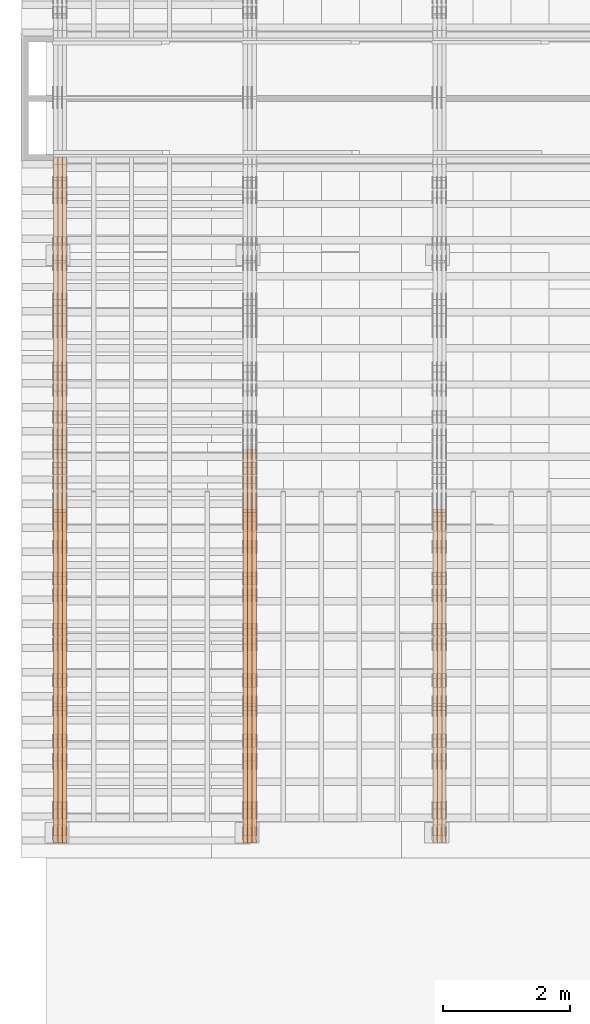
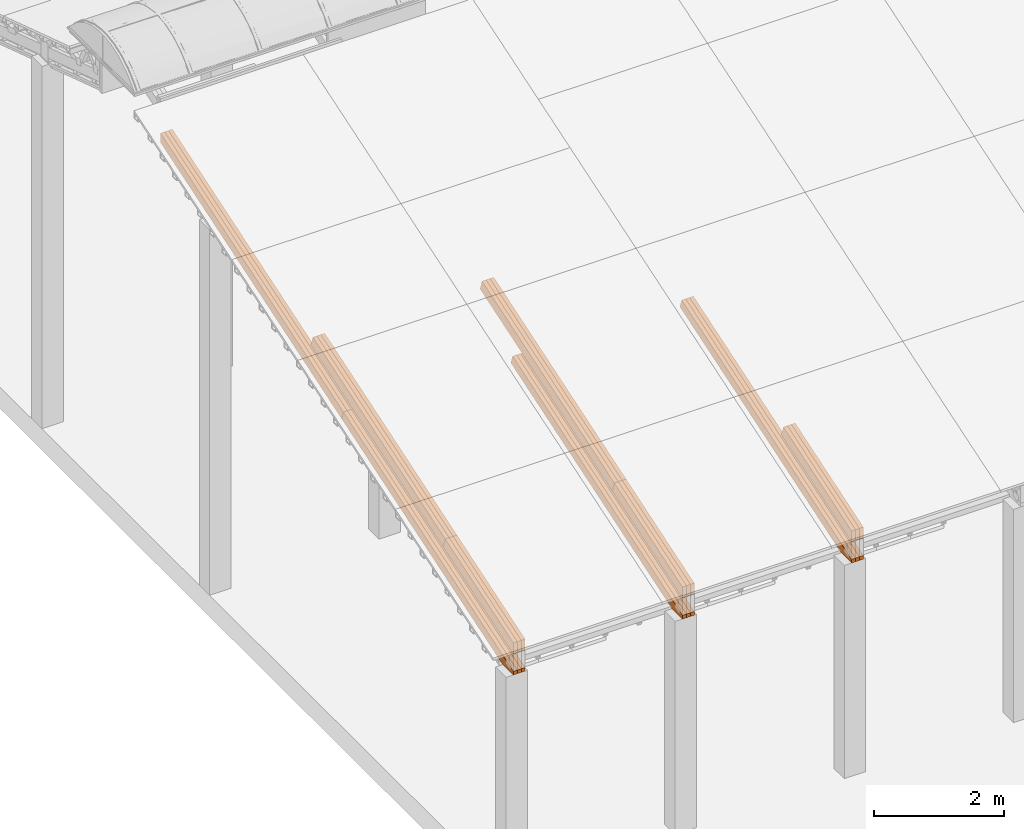
# One storey, part 11 of 385: 27 proxies.
"""IFC2X3 building model written with IfcOpenShell, lengths in millimetres."""

from ifc_helpers import new_model, entity, si_unit, converted_unit, derived_unit, direction, frame, origin, place, context, subcontext, project, spatial, polyline, outline, extrude, source, transform, mapped, material, type_object, type_shapes, element, save


model = new_model("IFC2X3")

# Units and contexts
model_context = context("Model", 3, precision=0.01, world=origin(), true_north=direction((6.12303176911189e-17, 1.0)))
body_context = subcontext(model_context, "Body", "Model", "MODEL_VIEW")
ifc_project = project(units=[si_unit("LENGTHUNIT", "METRE", prefix="MILLI"), si_unit("AREAUNIT", "SQUARE_METRE"), si_unit("VOLUMEUNIT", "CUBIC_METRE"), converted_unit("PLANEANGLEUNIT", "DEGREE", entity("IfcRatioMeasure", 0.0174532925199433), si_unit("PLANEANGLEUNIT", "RADIAN"), dimensions=[0, 0, 0, 0, 0, 0, 0]), si_unit("MASSUNIT", "GRAM", prefix="KILO"), derived_unit("MASSDENSITYUNIT", [(si_unit("MASSUNIT", "GRAM", prefix="KILO"), 1), (si_unit("LENGTHUNIT", "METRE"), -3)]), si_unit("TIMEUNIT", "SECOND"), si_unit("FREQUENCYUNIT", "HERTZ"), si_unit("THERMODYNAMICTEMPERATUREUNIT", "DEGREE_CELSIUS"), derived_unit("THERMALTRANSMITTANCEUNIT", [(si_unit("MASSUNIT", "GRAM", prefix="KILO"), 1), (si_unit("THERMODYNAMICTEMPERATUREUNIT", "KELVIN"), -1), (si_unit("TIMEUNIT", "SECOND"), -3)]), derived_unit("VOLUMETRICFLOWRATEUNIT", [(si_unit("LENGTHUNIT", "METRE"), 3), (si_unit("TIMEUNIT", "SECOND"), -1)]), si_unit("ELECTRICCURRENTUNIT", "AMPERE"), si_unit("ELECTRICVOLTAGEUNIT", "VOLT"), si_unit("POWERUNIT", "WATT"), si_unit("FORCEUNIT", "NEWTON", prefix="KILO"), si_unit("ILLUMINANCEUNIT", "LUX"), si_unit("LUMINOUSFLUXUNIT", "LUMEN"), si_unit("LUMINOUSINTENSITYUNIT", "CANDELA"), derived_unit("USERDEFINED", [(si_unit("MASSUNIT", "GRAM", prefix="KILO"), -1), (si_unit("LENGTHUNIT", "METRE"), -2), (si_unit("TIMEUNIT", "SECOND"), 3), (si_unit("LUMINOUSFLUXUNIT", "LUMEN"), 1)]), derived_unit("LINEARVELOCITYUNIT", [(si_unit("LENGTHUNIT", "METRE"), 1), (si_unit("TIMEUNIT", "SECOND"), -1)]), si_unit("PRESSUREUNIT", "PASCAL"), derived_unit("USERDEFINED", [(si_unit("LENGTHUNIT", "METRE"), -2), (si_unit("MASSUNIT", "GRAM", prefix="KILO"), 1), (si_unit("TIMEUNIT", "SECOND"), -2)])], contexts=[model_context])

# Site, building, storey
site_placement = place(None, origin())
site = spatial("IfcSite", under=ifc_project, at=site_placement, CompositionType="ELEMENT")
building_placement = place(site_placement, origin())
building = spatial("IfcBuilding", under=site, at=building_placement, CompositionType="ELEMENT")
storey_placement = place(building_placement, origin())
storey = spatial("IfcBuildingStorey", under=building, at=storey_placement, Name="Default", CompositionType="ELEMENT", Elevation=0.0)

# Proxies
ifc_material_1 = material(Name="IfcSurfaceStyle #76711")
building_element_proxy_type_1 = type_object("IfcBuildingElementProxyType", Name="T1-T3 76709", PredefinedType="NOTDEFINED", material=ifc_material_1)
shared_shape_1 = source(origin(), body_context, "Body", "SweptSolid", [
    extrude(outline(polyline([(-1085.54462735035, -97.5001496742589), (1117.22361141796, -97.5001496742589), (1117.22498157786, 97.5001496742589), (-1148.90396564547, 97.5001496742589), (-1085.54462735035, -97.5001496742589)])), frame((1117.22498157786, 97.5001496742589, 0.0), z_axis=(0.0, 0.0, 1.0), x_axis=(-1.0, 0.0, 0.0)), (0.0, 0.0, 1.0), 69.9999999999999),
])
type_shapes(building_element_proxy_type_1, [shared_shape_1])
proxy_1_placement = place(building_placement, frame((6385.0, 5095.216796875, 1095.23693847656), z_axis=(-1.0, 0.0, 0.0), x_axis=(0.0, -0.951056516295154, -0.309016994374948)))
element("IfcBuildingElementProxy", 1, at=proxy_1_placement, inside=storey, type_object=building_element_proxy_type_1, material=ifc_material_1, Name="T1-T3", context=body_context, shape_type="MappedRepresentation", body=[
    mapped(shared_shape_1, transform((0.0, 0.0, 0.0), scale=1.0)),
])
ifc_material_2 = material(Name="IfcSurfaceStyle #76654")
building_element_proxy_type_2 = type_object("IfcBuildingElementProxyType", Name="T1-T3 76652", PredefinedType="NOTDEFINED", material=ifc_material_2)
shared_shape_2 = source(origin(), body_context, "Body", "SweptSolid", [
    extrude(outline(polyline([(-1085.54462735035, -97.5001496742589), (1117.22361141796, -97.5001496742589), (1117.22498157786, 97.5001496742589), (-1148.90396564547, 97.5001496742589), (-1085.54462735035, -97.5001496742589)])), frame((1117.22498157786, 97.5001496742589, 0.0), z_axis=(0.0, 0.0, 1.0), x_axis=(-1.0, 0.0, 0.0)), (0.0, 0.0, 1.0), 69.9999999999999),
])
type_shapes(building_element_proxy_type_2, [shared_shape_2])
proxy_2_placement = place(building_placement, frame((6315.0, 5095.216796875, 1095.23693847656), z_axis=(-1.0, 0.0, 0.0), x_axis=(0.0, -0.951056516295154, -0.309016994374948)))
element("IfcBuildingElementProxy", 2, at=proxy_2_placement, inside=storey, type_object=building_element_proxy_type_2, material=ifc_material_2, Name="T1-T3", context=body_context, shape_type="MappedRepresentation", body=[
    mapped(shared_shape_2, transform((0.0, 0.0, 0.0), scale=1.0)),
])
ifc_material_3 = material(Name="IfcSurfaceStyle #76597")
building_element_proxy_type_3 = type_object("IfcBuildingElementProxyType", Name="T1-T3 76595", PredefinedType="NOTDEFINED", material=ifc_material_3)
shared_shape_3 = source(origin(), body_context, "Body", "SweptSolid", [
    extrude(outline(polyline([(-1085.54462735035, -97.5001496742589), (1117.22361141796, -97.5001496742589), (1117.22498157786, 97.5001496742589), (-1148.90396564547, 97.5001496742589), (-1085.54462735035, -97.5001496742589)])), frame((1117.22498157786, 97.5001496742589, 0.0), z_axis=(0.0, 0.0, 1.0), x_axis=(-1.0, 0.0, 0.0)), (0.0, 0.0, 1.0), 69.9999999999999),
])
type_shapes(building_element_proxy_type_3, [shared_shape_3])
proxy_3_placement = place(building_placement, frame((6245.0, 5095.216796875, 1095.23693847656), z_axis=(-1.0, 0.0, 0.0), x_axis=(0.0, -0.951056516295154, -0.309016994374948)))
element("IfcBuildingElementProxy", 3, at=proxy_3_placement, inside=storey, type_object=building_element_proxy_type_3, material=ifc_material_3, Name="T1-T3", context=body_context, shape_type="MappedRepresentation", body=[
    mapped(shared_shape_3, transform((0.0, 0.0, 0.0), scale=1.0)),
])
ifc_material_4 = material(Name="IfcSurfaceStyle #76027")
building_element_proxy_type_4 = type_object("IfcBuildingElementProxyType", Name="T1-B5 76025", PredefinedType="NOTDEFINED", material=ifc_material_4)
shared_shape_4 = source(origin(), body_context, "Body", "SweptSolid", [
    extrude(outline(polyline([(-3238.20553797979, -89.0131148793731), (1950.26357999126, -89.0131148793731), (2273.6227955316, 16.0525968934038), (2252.52438864378, 80.9868164326712), (-3238.20522618685, 80.9868164326712), (-3238.20553797979, -89.0131148793731)])), frame((2273.6227955316, 80.9869419088758, 0.0), z_axis=(0.0, 0.0, 1.0), x_axis=(-1.0, 0.0, 0.0)), (0.0, 0.0, 1.0), 69.9999999999997),
])
type_shapes(building_element_proxy_type_4, [shared_shape_4])
proxy_4_placement = place(building_placement, frame((6385.0, 2919.93418387161, 61.7562319586341), z_axis=(-1.0, 0.0, 0.0), x_axis=(0.0, 0.951056516295124, 0.309016994375039)))
element("IfcBuildingElementProxy", 4, at=proxy_4_placement, inside=storey, type_object=building_element_proxy_type_4, material=ifc_material_4, Name="T1-B5", context=body_context, shape_type="MappedRepresentation", body=[
    mapped(shared_shape_4, transform((0.0, 0.0, 0.0), scale=1.0)),
])
ifc_material_5 = material(Name="IfcSurfaceStyle #75961")
building_element_proxy_type_5 = type_object("IfcBuildingElementProxyType", Name="T1-B5 75959", PredefinedType="NOTDEFINED", material=ifc_material_5)
shared_shape_5 = source(origin(), body_context, "Body", "SweptSolid", [
    extrude(outline(polyline([(-3238.20553797979, -89.0131148793731), (1950.26357999126, -89.0131148793731), (2273.6227955316, 16.0525968934038), (2252.52438864378, 80.9868164326712), (-3238.20522618685, 80.9868164326712), (-3238.20553797979, -89.0131148793731)])), frame((2273.6227955316, 80.9869419088758, 0.0), z_axis=(0.0, 0.0, 1.0), x_axis=(-1.0, 0.0, 0.0)), (0.0, 0.0, 1.0), 69.9999999999997),
])
type_shapes(building_element_proxy_type_5, [shared_shape_5])
proxy_5_placement = place(building_placement, frame((6315.0, 2919.93418387161, 61.7562319586341), z_axis=(-1.0, 0.0, 0.0), x_axis=(0.0, 0.951056516295124, 0.309016994375039)))
element("IfcBuildingElementProxy", 5, at=proxy_5_placement, inside=storey, type_object=building_element_proxy_type_5, material=ifc_material_5, Name="T1-B5", context=body_context, shape_type="MappedRepresentation", body=[
    mapped(shared_shape_5, transform((0.0, 0.0, 0.0), scale=1.0)),
])
ifc_material_6 = material(Name="IfcSurfaceStyle #75895")
building_element_proxy_type_6 = type_object("IfcBuildingElementProxyType", Name="T1-B5 75893", PredefinedType="NOTDEFINED", material=ifc_material_6)
shared_shape_6 = source(origin(), body_context, "Body", "SweptSolid", [
    extrude(outline(polyline([(-3238.20553797979, -89.0131148793731), (1950.26357999126, -89.0131148793731), (2273.6227955316, 16.0525968934038), (2252.52438864378, 80.9868164326712), (-3238.20522618685, 80.9868164326712), (-3238.20553797979, -89.0131148793731)])), frame((2273.6227955316, 80.9869419088758, 0.0), z_axis=(0.0, 0.0, 1.0), x_axis=(-1.0, 0.0, 0.0)), (0.0, 0.0, 1.0), 69.9999999999997),
])
type_shapes(building_element_proxy_type_6, [shared_shape_6])
proxy_6_placement = place(building_placement, frame((6245.0, 2919.93418387161, 61.7562319586341), z_axis=(-1.0, 0.0, 0.0), x_axis=(0.0, 0.951056516295124, 0.309016994375039)))
element("IfcBuildingElementProxy", 6, at=proxy_6_placement, inside=storey, type_object=building_element_proxy_type_6, material=ifc_material_6, Name="T1-B5", context=body_context, shape_type="MappedRepresentation", body=[
    mapped(shared_shape_6, transform((0.0, 0.0, 0.0), scale=1.0)),
])
ifc_material_7 = material(Name="IfcSurfaceStyle #42279")
building_element_proxy_type_7 = type_object("IfcBuildingElementProxyType", Name="T1-T3 42277", PredefinedType="NOTDEFINED", material=ifc_material_7)
shared_shape_7 = source(origin(), body_context, "Body", "SweptSolid", [
    extrude(outline(polyline([(-1085.54462735035, -97.5001496742589), (1117.22361141796, -97.5001496742589), (1117.22498157786, 97.5001496742589), (-1148.90396564547, 97.5001496742589), (-1085.54462735035, -97.5001496742589)])), frame((1117.22498157786, 97.5001496742589, 0.0), z_axis=(0.0, 0.0, 1.0), x_axis=(-1.0, 0.0, 0.0)), (0.0, 0.0, 1.0), 69.9999999999999),
])
type_shapes(building_element_proxy_type_7, [shared_shape_7])
proxy_7_placement = place(building_placement, frame((3385.0, 5095.216796875, 1095.23693847656), z_axis=(-1.0, 0.0, 0.0), x_axis=(0.0, -0.951056516295154, -0.309016994374948)))
element("IfcBuildingElementProxy", 7, at=proxy_7_placement, inside=storey, type_object=building_element_proxy_type_7, material=ifc_material_7, Name="T1-T3", context=body_context, shape_type="MappedRepresentation", body=[
    mapped(shared_shape_7, transform((0.0, 0.0, 0.0), scale=1.0)),
])
ifc_material_8 = material(Name="IfcSurfaceStyle #42222")
building_element_proxy_type_8 = type_object("IfcBuildingElementProxyType", Name="T1-T3 42220", PredefinedType="NOTDEFINED", material=ifc_material_8)
shared_shape_8 = source(origin(), body_context, "Body", "SweptSolid", [
    extrude(outline(polyline([(-1085.54462735035, -97.5001496742589), (1117.22361141796, -97.5001496742589), (1117.22498157786, 97.5001496742589), (-1148.90396564547, 97.5001496742589), (-1085.54462735035, -97.5001496742589)])), frame((1117.22498157786, 97.5001496742589, 0.0), z_axis=(0.0, 0.0, 1.0), x_axis=(-1.0, 0.0, 0.0)), (0.0, 0.0, 1.0), 69.9999999999999),
])
type_shapes(building_element_proxy_type_8, [shared_shape_8])
proxy_8_placement = place(building_placement, frame((3315.0, 5095.216796875, 1095.23693847656), z_axis=(-1.0, 0.0, 0.0), x_axis=(0.0, -0.951056516295154, -0.309016994374948)))
element("IfcBuildingElementProxy", 8, at=proxy_8_placement, inside=storey, type_object=building_element_proxy_type_8, material=ifc_material_8, Name="T1-T3", context=body_context, shape_type="MappedRepresentation", body=[
    mapped(shared_shape_8, transform((0.0, 0.0, 0.0), scale=1.0)),
])
ifc_material_9 = material(Name="IfcSurfaceStyle #42165")
building_element_proxy_type_9 = type_object("IfcBuildingElementProxyType", Name="T1-T3 42163", PredefinedType="NOTDEFINED", material=ifc_material_9)
shared_shape_9 = source(origin(), body_context, "Body", "SweptSolid", [
    extrude(outline(polyline([(-1085.54462735035, -97.5001496742589), (1117.22361141796, -97.5001496742589), (1117.22498157786, 97.5001496742589), (-1148.90396564547, 97.5001496742589), (-1085.54462735035, -97.5001496742589)])), frame((1117.22498157786, 97.5001496742589, 0.0), z_axis=(0.0, 0.0, 1.0), x_axis=(-1.0, 0.0, 0.0)), (0.0, 0.0, 1.0), 69.9999999999999),
])
type_shapes(building_element_proxy_type_9, [shared_shape_9])
proxy_9_placement = place(building_placement, frame((3245.0, 5095.216796875, 1095.23693847656), z_axis=(-1.0, 0.0, 0.0), x_axis=(0.0, -0.951056516295154, -0.309016994374948)))
element("IfcBuildingElementProxy", 9, at=proxy_9_placement, inside=storey, type_object=building_element_proxy_type_9, material=ifc_material_9, Name="T1-T3", context=body_context, shape_type="MappedRepresentation", body=[
    mapped(shared_shape_9, transform((0.0, 0.0, 0.0), scale=1.0)),
])
ifc_material_10 = material(Name="IfcSurfaceStyle #42108")
building_element_proxy_type_10 = type_object("IfcBuildingElementProxyType", Name="T1-T2 42106", PredefinedType="NOTDEFINED", material=ifc_material_10)
shared_shape_10 = source(origin(), body_context, "Body", "SweptSolid", [
    extrude(outline(polyline([(-2137.04475371072, -97.5001541485635), (2137.04431231695, -97.5001541485635), (2137.0438249446, 97.5001541485636), (-2137.04338355082, 97.5001541485635), (-2137.04475371072, -97.5001541485635)])), frame((2137.04431231695, 97.5003268035489, 0.0), z_axis=(0.0, 0.0, 1.0), x_axis=(-1.0, 0.0, 0.0)), (0.0, 0.0, 1.0), 69.9999999999997),
])
type_shapes(building_element_proxy_type_10, [shared_shape_10])
proxy_10_placement = place(building_placement, frame((3385.0, 9160.11575124697, 2416.00267194857), z_axis=(-1.0, 0.0, 0.0), x_axis=(0.0, -0.951056516295154, -0.309016994374948)))
element("IfcBuildingElementProxy", 10, at=proxy_10_placement, inside=storey, type_object=building_element_proxy_type_10, material=ifc_material_10, Name="T1-T2", context=body_context, shape_type="MappedRepresentation", body=[
    mapped(shared_shape_10, transform((0.0, 0.0, 0.0), scale=1.0)),
])
ifc_material_11 = material(Name="IfcSurfaceStyle #42051")
building_element_proxy_type_11 = type_object("IfcBuildingElementProxyType", Name="T1-T2 42049", PredefinedType="NOTDEFINED", material=ifc_material_11)
shared_shape_11 = source(origin(), body_context, "Body", "SweptSolid", [
    extrude(outline(polyline([(-2137.04475371072, -97.5001541485635), (2137.04431231695, -97.5001541485635), (2137.0438249446, 97.5001541485636), (-2137.04338355082, 97.5001541485635), (-2137.04475371072, -97.5001541485635)])), frame((2137.04431231695, 97.5003268035489, 0.0), z_axis=(0.0, 0.0, 1.0), x_axis=(-1.0, 0.0, 0.0)), (0.0, 0.0, 1.0), 69.9999999999997),
])
type_shapes(building_element_proxy_type_11, [shared_shape_11])
proxy_11_placement = place(building_placement, frame((3315.0, 9160.11575124697, 2416.00267194857), z_axis=(-1.0, 0.0, 0.0), x_axis=(0.0, -0.951056516295154, -0.309016994374948)))
element("IfcBuildingElementProxy", 11, at=proxy_11_placement, inside=storey, type_object=building_element_proxy_type_11, material=ifc_material_11, Name="T1-T2", context=body_context, shape_type="MappedRepresentation", body=[
    mapped(shared_shape_11, transform((0.0, 0.0, 0.0), scale=1.0)),
])
ifc_material_12 = material(Name="IfcSurfaceStyle #41994")
building_element_proxy_type_12 = type_object("IfcBuildingElementProxyType", Name="T1-T2 41992", PredefinedType="NOTDEFINED", material=ifc_material_12)
shared_shape_12 = source(origin(), body_context, "Body", "SweptSolid", [
    extrude(outline(polyline([(-2137.04475371072, -97.5001541485635), (2137.04431231695, -97.5001541485635), (2137.0438249446, 97.5001541485636), (-2137.04338355082, 97.5001541485635), (-2137.04475371072, -97.5001541485635)])), frame((2137.04431231695, 97.5003268035489, 0.0), z_axis=(0.0, 0.0, 1.0), x_axis=(-1.0, 0.0, 0.0)), (0.0, 0.0, 1.0), 69.9999999999997),
])
type_shapes(building_element_proxy_type_12, [shared_shape_12])
proxy_12_placement = place(building_placement, frame((3245.0, 9160.11575124697, 2416.00267194857), z_axis=(-1.0, 0.0, 0.0), x_axis=(0.0, -0.951056516295154, -0.309016994374948)))
element("IfcBuildingElementProxy", 12, at=proxy_12_placement, inside=storey, type_object=building_element_proxy_type_12, material=ifc_material_12, Name="T1-T2", context=body_context, shape_type="MappedRepresentation", body=[
    mapped(shared_shape_12, transform((0.0, 0.0, 0.0), scale=1.0)),
])
ifc_material_13 = material(Name="IfcSurfaceStyle #41595")
building_element_proxy_type_13 = type_object("IfcBuildingElementProxyType", Name="T1-B5 41593", PredefinedType="NOTDEFINED", material=ifc_material_13)
shared_shape_13 = source(origin(), body_context, "Body", "SweptSolid", [
    extrude(outline(polyline([(-3238.20553797979, -89.0131148793731), (1950.26357999126, -89.0131148793731), (2273.6227955316, 16.0525968934038), (2252.52438864378, 80.9868164326712), (-3238.20522618685, 80.9868164326712), (-3238.20553797979, -89.0131148793731)])), frame((2273.6227955316, 80.9869419088758, 0.0), z_axis=(0.0, 0.0, 1.0), x_axis=(-1.0, 0.0, 0.0)), (0.0, 0.0, 1.0), 69.9999999999997),
])
type_shapes(building_element_proxy_type_13, [shared_shape_13])
proxy_13_placement = place(building_placement, frame((3385.0, 2919.93418387161, 61.7562319586341), z_axis=(-1.0, 0.0, 0.0), x_axis=(0.0, 0.951056516295124, 0.309016994375039)))
element("IfcBuildingElementProxy", 13, at=proxy_13_placement, inside=storey, type_object=building_element_proxy_type_13, material=ifc_material_13, Name="T1-B5", context=body_context, shape_type="MappedRepresentation", body=[
    mapped(shared_shape_13, transform((0.0, 0.0, 0.0), scale=1.0)),
])
ifc_material_14 = material(Name="IfcSurfaceStyle #41529")
building_element_proxy_type_14 = type_object("IfcBuildingElementProxyType", Name="T1-B5 41527", PredefinedType="NOTDEFINED", material=ifc_material_14)
shared_shape_14 = source(origin(), body_context, "Body", "SweptSolid", [
    extrude(outline(polyline([(-3238.20553797979, -89.0131148793731), (1950.26357999126, -89.0131148793731), (2273.6227955316, 16.0525968934038), (2252.52438864378, 80.9868164326712), (-3238.20522618685, 80.9868164326712), (-3238.20553797979, -89.0131148793731)])), frame((2273.6227955316, 80.9869419088758, 0.0), z_axis=(0.0, 0.0, 1.0), x_axis=(-1.0, 0.0, 0.0)), (0.0, 0.0, 1.0), 69.9999999999997),
])
type_shapes(building_element_proxy_type_14, [shared_shape_14])
proxy_14_placement = place(building_placement, frame((3315.0, 2919.93418387161, 61.7562319586341), z_axis=(-1.0, 0.0, 0.0), x_axis=(0.0, 0.951056516295124, 0.309016994375039)))
element("IfcBuildingElementProxy", 14, at=proxy_14_placement, inside=storey, type_object=building_element_proxy_type_14, material=ifc_material_14, Name="T1-B5", context=body_context, shape_type="MappedRepresentation", body=[
    mapped(shared_shape_14, transform((0.0, 0.0, 0.0), scale=1.0)),
])
ifc_material_15 = material(Name="IfcSurfaceStyle #41463")
building_element_proxy_type_15 = type_object("IfcBuildingElementProxyType", Name="T1-B5 41461", PredefinedType="NOTDEFINED", material=ifc_material_15)
shared_shape_15 = source(origin(), body_context, "Body", "SweptSolid", [
    extrude(outline(polyline([(-3238.20553797979, -89.0131148793731), (1950.26357999126, -89.0131148793731), (2273.6227955316, 16.0525968934038), (2252.52438864378, 80.9868164326712), (-3238.20522618685, 80.9868164326712), (-3238.20553797979, -89.0131148793731)])), frame((2273.6227955316, 80.9869419088758, 0.0), z_axis=(0.0, 0.0, 1.0), x_axis=(-1.0, 0.0, 0.0)), (0.0, 0.0, 1.0), 69.9999999999997),
])
type_shapes(building_element_proxy_type_15, [shared_shape_15])
proxy_15_placement = place(building_placement, frame((3245.0, 2919.93418387161, 61.7562319586341), z_axis=(-1.0, 0.0, 0.0), x_axis=(0.0, 0.951056516295124, 0.309016994375039)))
element("IfcBuildingElementProxy", 15, at=proxy_15_placement, inside=storey, type_object=building_element_proxy_type_15, material=ifc_material_15, Name="T1-B5", context=body_context, shape_type="MappedRepresentation", body=[
    mapped(shared_shape_15, transform((0.0, 0.0, 0.0), scale=1.0)),
])
ifc_material_16 = material(Name="IfcSurfaceStyle #7847")
building_element_proxy_type_16 = type_object("IfcBuildingElementProxyType", Name="T1-T3 7845", PredefinedType="NOTDEFINED", material=ifc_material_16)
shared_shape_16 = source(origin(), body_context, "Body", "SweptSolid", [
    extrude(outline(polyline([(-1085.54462735035, -97.5001496742589), (1117.22361141796, -97.5001496742589), (1117.22498157786, 97.5001496742589), (-1148.90396564547, 97.5001496742589), (-1085.54462735035, -97.5001496742589)])), frame((1117.22498157786, 97.5001496742589, 0.0), z_axis=(0.0, 0.0, 1.0), x_axis=(-1.0, 0.0, 0.0)), (0.0, 0.0, 1.0), 69.9999999999999),
])
type_shapes(building_element_proxy_type_16, [shared_shape_16])
proxy_16_placement = place(building_placement, frame((385.0, 5095.216796875, 1095.23693847656), z_axis=(-1.0, 0.0, 0.0), x_axis=(0.0, -0.951056516295154, -0.309016994374948)))
element("IfcBuildingElementProxy", 16, at=proxy_16_placement, inside=storey, type_object=building_element_proxy_type_16, material=ifc_material_16, Name="T1-T3", context=body_context, shape_type="MappedRepresentation", body=[
    mapped(shared_shape_16, transform((0.0, 0.0, 0.0), scale=1.0)),
])
ifc_material_17 = material(Name="IfcSurfaceStyle #7790")
building_element_proxy_type_17 = type_object("IfcBuildingElementProxyType", Name="T1-T3 7788", PredefinedType="NOTDEFINED", material=ifc_material_17)
shared_shape_17 = source(origin(), body_context, "Body", "SweptSolid", [
    extrude(outline(polyline([(-1085.54462735035, -97.5001496742589), (1117.22361141796, -97.5001496742589), (1117.22498157786, 97.5001496742589), (-1148.90396564547, 97.5001496742589), (-1085.54462735035, -97.5001496742589)])), frame((1117.22498157786, 97.5001496742589, 0.0), z_axis=(0.0, 0.0, 1.0), x_axis=(-1.0, 0.0, 0.0)), (0.0, 0.0, 1.0), 69.9999999999999),
])
type_shapes(building_element_proxy_type_17, [shared_shape_17])
proxy_17_placement = place(building_placement, frame((315.0, 5095.216796875, 1095.23693847656), z_axis=(-1.0, 0.0, 0.0), x_axis=(0.0, -0.951056516295154, -0.309016994374948)))
element("IfcBuildingElementProxy", 17, at=proxy_17_placement, inside=storey, type_object=building_element_proxy_type_17, material=ifc_material_17, Name="T1-T3", context=body_context, shape_type="MappedRepresentation", body=[
    mapped(shared_shape_17, transform((0.0, 0.0, 0.0), scale=1.0)),
])
ifc_material_18 = material(Name="IfcSurfaceStyle #7733")
building_element_proxy_type_18 = type_object("IfcBuildingElementProxyType", Name="T1-T3 7731", PredefinedType="NOTDEFINED", material=ifc_material_18)
shared_shape_18 = source(origin(), body_context, "Body", "SweptSolid", [
    extrude(outline(polyline([(-1085.54462735035, -97.5001496742589), (1117.22361141796, -97.5001496742589), (1117.22498157786, 97.5001496742589), (-1148.90396564547, 97.5001496742589), (-1085.54462735035, -97.5001496742589)])), frame((1117.22498157786, 97.5001496742589, 0.0), z_axis=(0.0, 0.0, 1.0), x_axis=(-1.0, 0.0, 0.0)), (0.0, 0.0, 1.0), 69.9999999999999),
])
type_shapes(building_element_proxy_type_18, [shared_shape_18])
proxy_18_placement = place(building_placement, frame((245.0, 5095.216796875, 1095.23693847656), z_axis=(-1.0, 0.0, 0.0), x_axis=(0.0, -0.951056516295154, -0.309016994374948)))
element("IfcBuildingElementProxy", 18, at=proxy_18_placement, inside=storey, type_object=building_element_proxy_type_18, material=ifc_material_18, Name="T1-T3", context=body_context, shape_type="MappedRepresentation", body=[
    mapped(shared_shape_18, transform((0.0, 0.0, 0.0), scale=1.0)),
])
ifc_material_19 = material(Name="IfcSurfaceStyle #7676")
building_element_proxy_type_19 = type_object("IfcBuildingElementProxyType", Name="T1-T2 7674", PredefinedType="NOTDEFINED", material=ifc_material_19)
shared_shape_19 = source(origin(), body_context, "Body", "SweptSolid", [
    extrude(outline(polyline([(-2137.04475371072, -97.5001541485635), (2137.04431231695, -97.5001541485635), (2137.0438249446, 97.5001541485636), (-2137.04338355082, 97.5001541485635), (-2137.04475371072, -97.5001541485635)])), frame((2137.04431231695, 97.5003268035489, 0.0), z_axis=(0.0, 0.0, 1.0), x_axis=(-1.0, 0.0, 0.0)), (0.0, 0.0, 1.0), 69.9999999999997),
])
type_shapes(building_element_proxy_type_19, [shared_shape_19])
proxy_19_placement = place(building_placement, frame((385.0, 9160.11575124697, 2416.00267194857), z_axis=(-1.0, 0.0, 0.0), x_axis=(0.0, -0.951056516295154, -0.309016994374948)))
element("IfcBuildingElementProxy", 19, at=proxy_19_placement, inside=storey, type_object=building_element_proxy_type_19, material=ifc_material_19, Name="T1-T2", context=body_context, shape_type="MappedRepresentation", body=[
    mapped(shared_shape_19, transform((0.0, 0.0, 0.0), scale=1.0)),
])
ifc_material_20 = material(Name="IfcSurfaceStyle #7619")
building_element_proxy_type_20 = type_object("IfcBuildingElementProxyType", Name="T1-T2 7617", PredefinedType="NOTDEFINED", material=ifc_material_20)
shared_shape_20 = source(origin(), body_context, "Body", "SweptSolid", [
    extrude(outline(polyline([(-2137.04475371072, -97.5001541485635), (2137.04431231695, -97.5001541485635), (2137.0438249446, 97.5001541485636), (-2137.04338355082, 97.5001541485635), (-2137.04475371072, -97.5001541485635)])), frame((2137.04431231695, 97.5003268035489, 0.0), z_axis=(0.0, 0.0, 1.0), x_axis=(-1.0, 0.0, 0.0)), (0.0, 0.0, 1.0), 69.9999999999997),
])
type_shapes(building_element_proxy_type_20, [shared_shape_20])
proxy_20_placement = place(building_placement, frame((315.0, 9160.11575124697, 2416.00267194857), z_axis=(-1.0, 0.0, 0.0), x_axis=(0.0, -0.951056516295154, -0.309016994374948)))
element("IfcBuildingElementProxy", 20, at=proxy_20_placement, inside=storey, type_object=building_element_proxy_type_20, material=ifc_material_20, Name="T1-T2", context=body_context, shape_type="MappedRepresentation", body=[
    mapped(shared_shape_20, transform((0.0, 0.0, 0.0), scale=1.0)),
])
ifc_material_21 = material(Name="IfcSurfaceStyle #7562")
building_element_proxy_type_21 = type_object("IfcBuildingElementProxyType", Name="T1-T2 7560", PredefinedType="NOTDEFINED", material=ifc_material_21)
shared_shape_21 = source(origin(), body_context, "Body", "SweptSolid", [
    extrude(outline(polyline([(-2137.04475371072, -97.5001541485635), (2137.04431231695, -97.5001541485635), (2137.0438249446, 97.5001541485636), (-2137.04338355082, 97.5001541485635), (-2137.04475371072, -97.5001541485635)])), frame((2137.04431231695, 97.5003268035489, 0.0), z_axis=(0.0, 0.0, 1.0), x_axis=(-1.0, 0.0, 0.0)), (0.0, 0.0, 1.0), 69.9999999999997),
])
type_shapes(building_element_proxy_type_21, [shared_shape_21])
proxy_21_placement = place(building_placement, frame((245.0, 9160.11575124697, 2416.00267194857), z_axis=(-1.0, 0.0, 0.0), x_axis=(0.0, -0.951056516295154, -0.309016994374948)))
element("IfcBuildingElementProxy", 21, at=proxy_21_placement, inside=storey, type_object=building_element_proxy_type_21, material=ifc_material_21, Name="T1-T2", context=body_context, shape_type="MappedRepresentation", body=[
    mapped(shared_shape_21, transform((0.0, 0.0, 0.0), scale=1.0)),
])
ifc_material_22 = material(Name="IfcSurfaceStyle #7334")
building_element_proxy_type_22 = type_object("IfcBuildingElementProxyType", Name="T1-B4 7332", PredefinedType="NOTDEFINED", material=ifc_material_22)
shared_shape_22 = source(origin(), body_context, "Body", "SweptSolid", [
    extrude(outline(polyline([(-2912.13310129284, -85.0000958683222), (2939.75111293783, -85.0000958683222), (2939.75142473078, 85.0000958683222), (-2967.36943637577, 85.0000958683222), (-2912.13310129284, -85.0000958683222)])), frame((2939.75142473078, 85.0000958683222, 0.0), z_axis=(0.0, 0.0, 1.0), x_axis=(-1.0, 0.0, 0.0)), (0.0, 0.0, 1.0), 69.9999999999996),
])
type_shapes(building_element_proxy_type_22, [shared_shape_22])
proxy_22_placement = place(building_placement, frame((385.0, 8161.994140625, 1765.00476074219), z_axis=(-1.0, 0.0, 0.0), x_axis=(0.0, 0.951056516295124, 0.309016994375039)))
element("IfcBuildingElementProxy", 22, at=proxy_22_placement, inside=storey, type_object=building_element_proxy_type_22, material=ifc_material_22, Name="T1-B4", context=body_context, shape_type="MappedRepresentation", body=[
    mapped(shared_shape_22, transform((0.0, 0.0, 0.0), scale=1.0)),
])
ifc_material_23 = material(Name="IfcSurfaceStyle #7277")
building_element_proxy_type_23 = type_object("IfcBuildingElementProxyType", Name="T1-B4 7275", PredefinedType="NOTDEFINED", material=ifc_material_23)
shared_shape_23 = source(origin(), body_context, "Body", "SweptSolid", [
    extrude(outline(polyline([(-2912.13310129284, -85.0000958683222), (2939.75111293783, -85.0000958683222), (2939.75142473078, 85.0000958683222), (-2967.36943637577, 85.0000958683222), (-2912.13310129284, -85.0000958683222)])), frame((2939.75142473078, 85.0000958683222, 0.0), z_axis=(0.0, 0.0, 1.0), x_axis=(-1.0, 0.0, 0.0)), (0.0, 0.0, 1.0), 69.9999999999996),
])
type_shapes(building_element_proxy_type_23, [shared_shape_23])
proxy_23_placement = place(building_placement, frame((315.0, 8161.994140625, 1765.00476074219), z_axis=(-1.0, 0.0, 0.0), x_axis=(0.0, 0.951056516295124, 0.309016994375039)))
element("IfcBuildingElementProxy", 23, at=proxy_23_placement, inside=storey, type_object=building_element_proxy_type_23, material=ifc_material_23, Name="T1-B4", context=body_context, shape_type="MappedRepresentation", body=[
    mapped(shared_shape_23, transform((0.0, 0.0, 0.0), scale=1.0)),
])
ifc_material_24 = material(Name="IfcSurfaceStyle #7220")
building_element_proxy_type_24 = type_object("IfcBuildingElementProxyType", Name="T1-B4 7218", PredefinedType="NOTDEFINED", material=ifc_material_24)
shared_shape_24 = source(origin(), body_context, "Body", "SweptSolid", [
    extrude(outline(polyline([(-2912.13310129284, -85.0000958683222), (2939.75111293783, -85.0000958683222), (2939.75142473078, 85.0000958683222), (-2967.36943637577, 85.0000958683222), (-2912.13310129284, -85.0000958683222)])), frame((2939.75142473078, 85.0000958683222, 0.0), z_axis=(0.0, 0.0, 1.0), x_axis=(-1.0, 0.0, 0.0)), (0.0, 0.0, 1.0), 69.9999999999996),
])
type_shapes(building_element_proxy_type_24, [shared_shape_24])
proxy_24_placement = place(building_placement, frame((245.0, 8161.994140625, 1765.00476074219), z_axis=(-1.0, 0.0, 0.0), x_axis=(0.0, 0.951056516295124, 0.309016994375039)))
element("IfcBuildingElementProxy", 24, at=proxy_24_placement, inside=storey, type_object=building_element_proxy_type_24, material=ifc_material_24, Name="T1-B4", context=body_context, shape_type="MappedRepresentation", body=[
    mapped(shared_shape_24, transform((0.0, 0.0, 0.0), scale=1.0)),
])
ifc_material_25 = material(Name="IfcSurfaceStyle #7163")
building_element_proxy_type_25 = type_object("IfcBuildingElementProxyType", Name="T1-B5 7161", PredefinedType="NOTDEFINED", material=ifc_material_25)
shared_shape_25 = source(origin(), body_context, "Body", "SweptSolid", [
    extrude(outline(polyline([(-3238.20553797979, -89.0131148793731), (1950.26357999126, -89.0131148793731), (2273.6227955316, 16.0525968934038), (2252.52438864378, 80.9868164326712), (-3238.20522618685, 80.9868164326712), (-3238.20553797979, -89.0131148793731)])), frame((2273.6227955316, 80.9869419088758, 0.0), z_axis=(0.0, 0.0, 1.0), x_axis=(-1.0, 0.0, 0.0)), (0.0, 0.0, 1.0), 69.9999999999997),
])
type_shapes(building_element_proxy_type_25, [shared_shape_25])
proxy_25_placement = place(building_placement, frame((385.0, 2919.93418387161, 61.7562319586341), z_axis=(-1.0, 0.0, 0.0), x_axis=(0.0, 0.951056516295124, 0.309016994375039)))
element("IfcBuildingElementProxy", 25, at=proxy_25_placement, inside=storey, type_object=building_element_proxy_type_25, material=ifc_material_25, Name="T1-B5", context=body_context, shape_type="MappedRepresentation", body=[
    mapped(shared_shape_25, transform((0.0, 0.0, 0.0), scale=1.0)),
])
ifc_material_26 = material(Name="IfcSurfaceStyle #7097")
building_element_proxy_type_26 = type_object("IfcBuildingElementProxyType", Name="T1-B5 7095", PredefinedType="NOTDEFINED", material=ifc_material_26)
shared_shape_26 = source(origin(), body_context, "Body", "SweptSolid", [
    extrude(outline(polyline([(-3238.20553797979, -89.0131148793731), (1950.26357999126, -89.0131148793731), (2273.6227955316, 16.0525968934038), (2252.52438864378, 80.9868164326712), (-3238.20522618685, 80.9868164326712), (-3238.20553797979, -89.0131148793731)])), frame((2273.6227955316, 80.9869419088758, 0.0), z_axis=(0.0, 0.0, 1.0), x_axis=(-1.0, 0.0, 0.0)), (0.0, 0.0, 1.0), 69.9999999999997),
])
type_shapes(building_element_proxy_type_26, [shared_shape_26])
proxy_26_placement = place(building_placement, frame((315.0, 2919.93418387161, 61.7562319586341), z_axis=(-1.0, 0.0, 0.0), x_axis=(0.0, 0.951056516295124, 0.309016994375039)))
element("IfcBuildingElementProxy", 26, at=proxy_26_placement, inside=storey, type_object=building_element_proxy_type_26, material=ifc_material_26, Name="T1-B5", context=body_context, shape_type="MappedRepresentation", body=[
    mapped(shared_shape_26, transform((0.0, 0.0, 0.0), scale=1.0)),
])
ifc_material_27 = material(Name="IfcSurfaceStyle #7031")
building_element_proxy_type_27 = type_object("IfcBuildingElementProxyType", Name="T1-B5 7029", PredefinedType="NOTDEFINED", material=ifc_material_27)
shared_shape_27 = source(origin(), body_context, "Body", "SweptSolid", [
    extrude(outline(polyline([(-3238.20553797979, -89.0131148793731), (1950.26357999126, -89.0131148793731), (2273.6227955316, 16.0525968934038), (2252.52438864378, 80.9868164326712), (-3238.20522618685, 80.9868164326712), (-3238.20553797979, -89.0131148793731)])), frame((2273.6227955316, 80.9869419088758, 0.0), z_axis=(0.0, 0.0, 1.0), x_axis=(-1.0, 0.0, 0.0)), (0.0, 0.0, 1.0), 69.9999999999997),
])
type_shapes(building_element_proxy_type_27, [shared_shape_27])
proxy_27_placement = place(building_placement, frame((245.0, 2919.93418387161, 61.7562319586341), z_axis=(-1.0, 0.0, 0.0), x_axis=(0.0, 0.951056516295124, 0.309016994375039)))
element("IfcBuildingElementProxy", 27, at=proxy_27_placement, inside=storey, type_object=building_element_proxy_type_27, material=ifc_material_27, Name="T1-B5", context=body_context, shape_type="MappedRepresentation", body=[
    mapped(shared_shape_27, transform((0.0, 0.0, 0.0), scale=1.0)),
])

save(model, "model.ifc")
